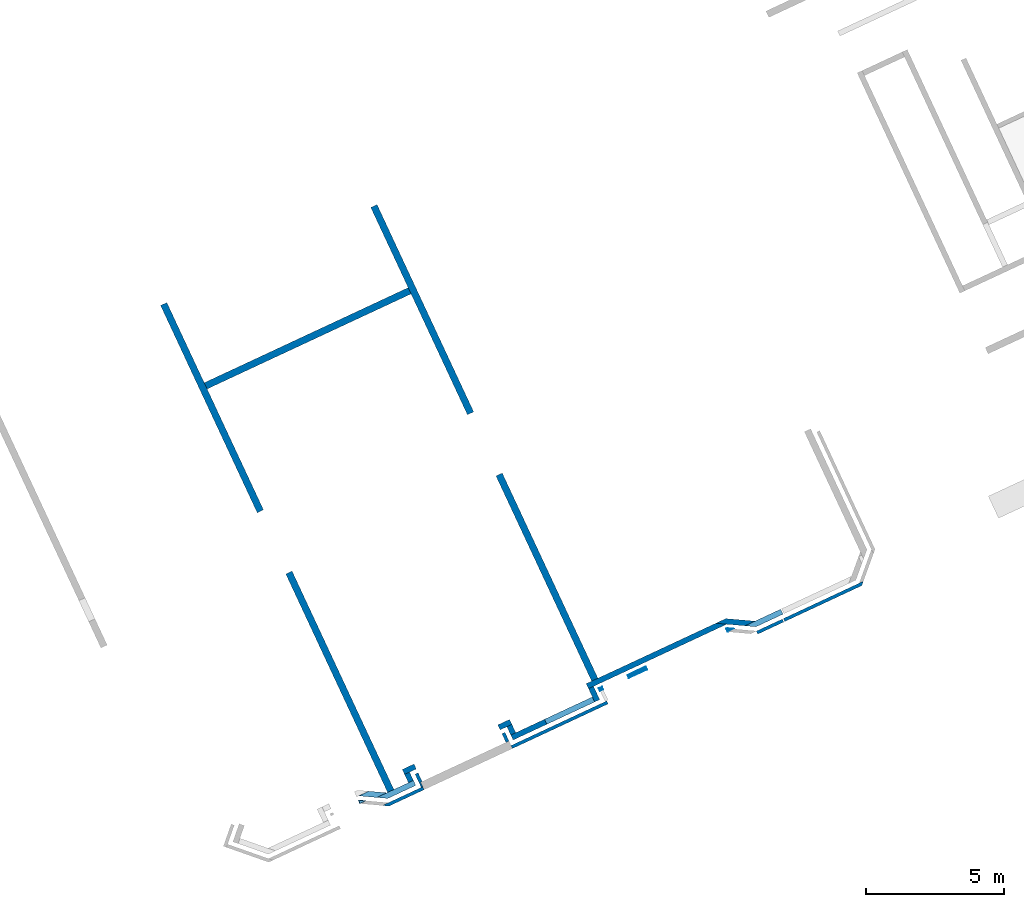
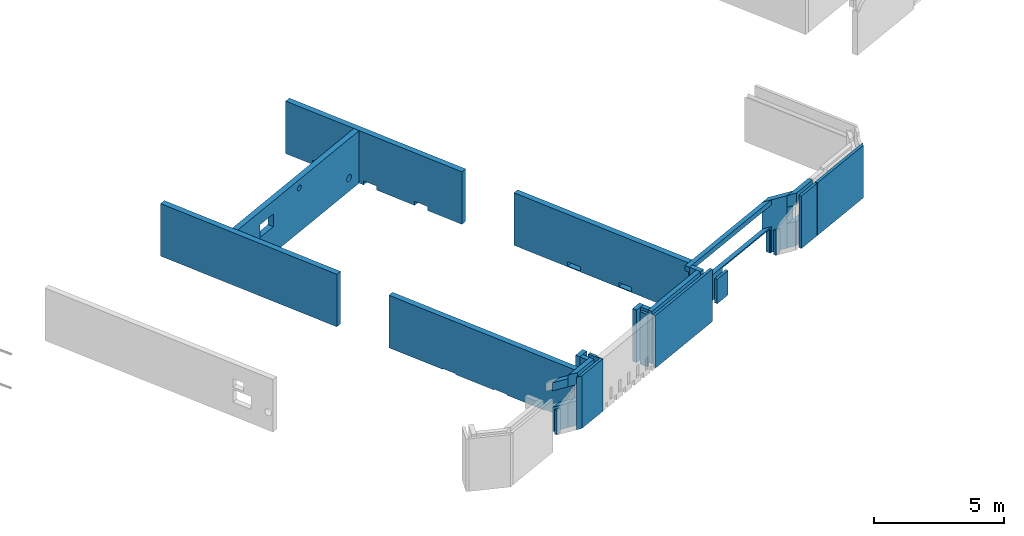
# One storey, part 2 of 13: 24 walls, 23 openings.
"""IFC2X3 building model written with IfcOpenShell, lengths in metres."""

from ifc_helpers import new_model, entity, si_unit, converted_unit, derived_unit, direction, frame, frame_2d, origin, origin_2d_with_axis, place, context, subcontext, project, spatial, polyline, rectangle, circle, outline, extrude, clip, halfspace, bounded_halfspace, material, layer, layer_set, layer_usage, type_object, element, save


model = new_model("IFC2X3")

# Units and contexts
model_context = context("Model", 3, precision=1e-05, world=origin(), true_north=direction((6.12303176911189e-17, 1.0)))
body_context = subcontext(model_context, "Body", "Model", "MODEL_VIEW")
ifc_project = project(units=[si_unit("LENGTHUNIT", "METRE"), si_unit("AREAUNIT", "SQUARE_METRE"), si_unit("VOLUMEUNIT", "CUBIC_METRE"), converted_unit("PLANEANGLEUNIT", "DEGREE", entity("IfcRatioMeasure", 0.0174532925199433), si_unit("PLANEANGLEUNIT", "RADIAN"), dimensions=[0, 0, 0, 0, 0, 0, 0]), si_unit("MASSUNIT", "GRAM", prefix="KILO"), derived_unit("MASSDENSITYUNIT", [(si_unit("MASSUNIT", "GRAM", prefix="KILO"), 1), (si_unit("LENGTHUNIT", "METRE"), -3)]), si_unit("TIMEUNIT", "SECOND"), si_unit("FREQUENCYUNIT", "HERTZ"), si_unit("THERMODYNAMICTEMPERATUREUNIT", "DEGREE_CELSIUS"), derived_unit("THERMALTRANSMITTANCEUNIT", [(si_unit("MASSUNIT", "GRAM", prefix="KILO"), 1), (si_unit("THERMODYNAMICTEMPERATUREUNIT", "KELVIN"), -1), (si_unit("TIMEUNIT", "SECOND"), -3)]), derived_unit("VOLUMETRICFLOWRATEUNIT", [(si_unit("LENGTHUNIT", "METRE"), 3), (si_unit("TIMEUNIT", "SECOND"), -1)]), si_unit("ELECTRICCURRENTUNIT", "AMPERE"), si_unit("ELECTRICVOLTAGEUNIT", "VOLT"), si_unit("POWERUNIT", "WATT"), si_unit("FORCEUNIT", "NEWTON", prefix="KILO"), si_unit("ILLUMINANCEUNIT", "LUX"), si_unit("LUMINOUSFLUXUNIT", "LUMEN"), si_unit("LUMINOUSINTENSITYUNIT", "CANDELA"), derived_unit("USERDEFINED", [(si_unit("MASSUNIT", "GRAM", prefix="KILO"), -1), (si_unit("LENGTHUNIT", "METRE"), -2), (si_unit("TIMEUNIT", "SECOND"), 3), (si_unit("LUMINOUSFLUXUNIT", "LUMEN"), 1)]), derived_unit("LINEARVELOCITYUNIT", [(si_unit("LENGTHUNIT", "METRE"), 1), (si_unit("TIMEUNIT", "SECOND"), -1)]), si_unit("PRESSUREUNIT", "PASCAL"), derived_unit("USERDEFINED", [(si_unit("LENGTHUNIT", "METRE"), -2), (si_unit("MASSUNIT", "GRAM", prefix="KILO"), 1), (si_unit("TIMEUNIT", "SECOND"), -2)])], contexts=[model_context])

# Site, building, storey
site_placement = place(None, frame((5.36960000000003, 43.3158000000006, 0.0), z_axis=(0.0, 0.0, 1.0), x_axis=(-0.422618261740703, 0.906307787036648, 0.0)))
site = spatial("IfcSite", under=ifc_project, at=site_placement, CompositionType="ELEMENT")
building_placement = place(site_placement, origin())
building = spatial("IfcBuilding", under=site, at=building_placement, CompositionType="ELEMENT")
storey_placement = place(building_placement, frame((0.0, 0.0, 2.56)))
storey = spatial("IfcBuildingStorey", under=building, at=storey_placement, CompositionType="ELEMENT", Elevation=2.56)

# Wall
ifc_material_1 = material(Name="C30/37 XC1")
ifc_layer_1 = layer(ifc_material_1, 0.25)
ifc_layer_set_1 = layer_set([ifc_layer_1])
ifc_layer_usage_1 = layer_usage(ifc_layer_set_1, "AXIS2", "NEGATIVE", 0.125)
wall_type_1 = type_object("IfcWallType", PredefinedType="NOTDEFINED", material=ifc_layer_set_1)
wall_1_placement = place(storey_placement, frame((11.6451948234783, 43.2325258490259, 0.0)))
element("IfcWallStandardCase", 1, at=wall_1_placement, inside=storey, type_object=wall_type_1, material=ifc_layer_usage_1, Name="XS1", context=body_context, shape_type="Clipping", body=[
    clip(extrude(rectangle(XDim=8.28555777301309, YDim=0.249999999999995, at=frame_2d((4.14277888650655, -1.9220736113823e-15), x_axis=(-1.0, 0.0))), origin(), (0.0, 0.0, 1.0), 2.47), halfspace(frame((0.0, 0.0, -2.56)), True)),
])

# Wall, openings
ifc_layer_usage_2 = layer_usage(ifc_layer_set_1, "AXIS2", "NEGATIVE", 0.125)
wall_2_placement = place(storey_placement, frame((0.470660848237759, 43.232525849026, 0.0)))
wall_2 = element("IfcWallStandardCase", 2, at=wall_2_placement, inside=storey, type_object=wall_type_1, material=ifc_layer_usage_2, Name="XS1", context=body_context, shape_type="Clipping", body=[
    clip(extrude(rectangle(XDim=8.73000078564873, YDim=0.249999999999995, at=frame_2d((4.36500039282437, -1.66533453693773e-16), x_axis=(-1.0, 0.0))), origin(), (0.0, 0.0, 1.0), 2.47), halfspace(frame((0.0, 0.0, -2.56)), True)),
])
opening_1_placement = place(wall_2_placement, origin())
element("IfcOpeningElement", 3, at=opening_1_placement, cuts=wall_2, Name="XS1", ObjectType="Opening", context=body_context, shape_type="SweptSolid", body=[
    extrude(rectangle(XDim=0.2, YDim=0.6, at=frame_2d((0.0, -2.70616862252382e-16), x_axis=(0.0, 1.0))), frame((1.09611385664153, -1.39899999999999, -0.0599998535014134), z_axis=(0.0, 1.0, 0.0), x_axis=(-1.0, 0.0, 0.0)), (0.0, 0.0, 1.0), 3.048),
])
opening_2_placement = place(wall_2_placement, origin())
element("IfcOpeningElement", 4, at=opening_2_placement, cuts=wall_2, Name="XS1", ObjectType="Opening", context=body_context, shape_type="SweptSolid", body=[
    extrude(rectangle(XDim=0.199999999999999, YDim=0.6, at=frame_2d((0.0, 2.70616862252382e-16), x_axis=(0.0, 1.0))), frame((3.49611385664154, -1.39899999999999, -0.0599998535014101), z_axis=(0.0, 1.0, 0.0), x_axis=(-1.0, 0.0, 0.0)), (0.0, 0.0, 1.0), 3.048),
])
opening_3_placement = place(wall_2_placement, origin())
element("IfcOpeningElement", 5, at=opening_3_placement, cuts=wall_2, Name="XS1", ObjectType="Opening", context=body_context, shape_type="SweptSolid", body=[
    extrude(rectangle(XDim=0.2, YDim=0.6, at=frame_2d((0.0, -2.70616862252382e-16), x_axis=(0.0, 1.0))), frame((5.89612088386859, -1.39899999999999, -0.0599998535014058), z_axis=(0.0, 1.0, 0.0), x_axis=(-1.0, 0.0, 0.0)), (0.0, 0.0, 1.0), 3.048),
])

ifc_layer_usage_3 = layer_usage(ifc_layer_set_1, "AXIS2", "NEGATIVE", 0.125)
wall_3_placement = place(storey_placement, frame((11.6451948234783, 34.8325258490247, 0.0)))
wall_3 = element("IfcWallStandardCase", 6, at=wall_3_placement, inside=storey, type_object=wall_type_1, material=ifc_layer_usage_3, Name="XS1", context=body_context, shape_type="Clipping", body=[
    clip(extrude(rectangle(XDim=8.28555777301365, YDim=0.250000000000004, at=frame_2d((4.14277888650682, 2.35922392732846e-16), x_axis=(-1.0, 0.0))), origin(), (0.0, 0.0, 1.0), 2.47), halfspace(frame((0.0, 0.0, -2.56)), True)),
])
opening_4_placement = place(wall_3_placement, origin())
element("IfcOpeningElement", 7, at=opening_4_placement, cuts=wall_3, Name="XS1", ObjectType="Opening", context=body_context, shape_type="SweptSolid", body=[
    extrude(rectangle(XDim=0.2, YDim=0.6, at=frame_2d((-1.08246744900953e-15, -2.70616862252382e-16), x_axis=(0.0, 1.0))), frame((1.92155925180208, -1.39899999999999, 0.0900000718130875), z_axis=(0.0, 1.0, 0.0), x_axis=(-1.0, 0.0, 0.0)), (0.0, 0.0, 1.0), 3.048),
])
opening_5_placement = place(wall_3_placement, origin())
element("IfcOpeningElement", 8, at=opening_5_placement, cuts=wall_3, Name="XS1", ObjectType="Opening", context=body_context, shape_type="SweptSolid", body=[
    extrude(rectangle(XDim=0.199999999999999, YDim=0.6, at=frame_2d((-1.08246744900953e-15, 2.70616862252382e-16), x_axis=(0.0, 1.0))), frame((4.32155925180209, -1.399, 0.0900000718130908), z_axis=(0.0, 1.0, 0.0), x_axis=(-1.0, 0.0, 0.0)), (0.0, 0.0, 1.0), 3.048),
])
opening_6_placement = place(wall_3_placement, origin())
element("IfcOpeningElement", 9, at=opening_6_placement, cuts=wall_3, Name="XS1", ObjectType="Opening", context=body_context, shape_type="SweptSolid", body=[
    extrude(rectangle(XDim=0.2, YDim=0.6, at=frame_2d((-1.08246744900953e-15, -2.70616862252382e-16), x_axis=(0.0, 1.0))), frame((6.72157988490444, -1.399, 0.0900000718130951), z_axis=(0.0, 1.0, 0.0), x_axis=(-1.0, 0.0, 0.0)), (0.0, 0.0, 1.0), 3.048),
])

ifc_layer_usage_4 = layer_usage(ifc_layer_set_1, "AXIS2", "NEGATIVE", 0.125)
wall_4_placement = place(storey_placement, frame((1.00066044225106, 34.8325258490248, 0.0)))
wall_4 = element("IfcWallStandardCase", 10, at=wall_4_placement, inside=storey, type_object=wall_type_1, material=ifc_layer_usage_4, Name="XS1", context=body_context, shape_type="Clipping", body=[
    clip(extrude(rectangle(XDim=8.20000119163591, YDim=0.250000000000004, at=frame_2d((4.10000059581795, -9.71445146547012e-17), x_axis=(-1.0, 0.0))), origin(), (0.0, 0.0, 1.0), 2.47), halfspace(frame((0.0, 0.0, -2.56)), True)),
])
opening_7_placement = place(wall_4_placement, origin())
element("IfcOpeningElement", 11, at=opening_7_placement, cuts=wall_4, Name="XS1", ObjectType="Opening", context=body_context, shape_type="SweptSolid", body=[
    extrude(rectangle(XDim=0.2, YDim=0.6, at=frame_2d((0.0, -2.70616862252382e-16), x_axis=(0.0, 1.0))), frame((0.5661142768775, -1.399, 0.140000071813087), z_axis=(0.0, 1.0, 0.0), x_axis=(-1.0, 0.0, 0.0)), (0.0, 0.0, 1.0), 3.048),
])
opening_8_placement = place(wall_4_placement, origin())
element("IfcOpeningElement", 12, at=opening_8_placement, cuts=wall_4, Name="XS1", ObjectType="Opening", context=body_context, shape_type="SweptSolid", body=[
    extrude(rectangle(XDim=0.199999999999999, YDim=0.6, at=frame_2d((0.0, 2.70616862252382e-16), x_axis=(0.0, 1.0))), frame((2.96611427687751, -1.399, 0.14000007181309), z_axis=(0.0, 1.0, 0.0), x_axis=(-1.0, 0.0, 0.0)), (0.0, 0.0, 1.0), 3.048),
])
opening_9_placement = place(wall_4_placement, origin())
element("IfcOpeningElement", 13, at=opening_9_placement, cuts=wall_4, Name="XS1", ObjectType="Opening", context=body_context, shape_type="SweptSolid", body=[
    extrude(rectangle(XDim=0.2, YDim=0.6, at=frame_2d((0.0, -2.70616862252382e-16), x_axis=(0.0, 1.0))), frame((5.36988490365039, -1.399, 0.140000071813095), z_axis=(0.0, 1.0, 0.0), x_axis=(-1.0, 0.0, 0.0)), (0.0, 0.0, 1.0), 3.048),
])

ifc_layer_usage_5 = layer_usage(ifc_layer_set_1, "AXIS2", "NEGATIVE", 0.125)
wall_5_placement = place(storey_placement, frame((16.6006608482378, 43.1075258490258, 0.0), z_axis=(0.0, 0.0, 1.0), x_axis=(0.0, -1.0, 0.0)))
wall_5 = element("IfcWallStandardCase", 14, at=wall_5_placement, inside=storey, type_object=wall_type_1, material=ifc_layer_usage_5, context=body_context, shape_type="Clipping", body=[
    clip(extrude(rectangle(XDim=8.15000000000114, YDim=0.25, at=frame_2d((4.07500000000057, -2.91433543964104e-16), x_axis=(-1.0, 0.0))), origin(), (0.0, 0.0, 1.0), 2.47), halfspace(frame((0.0, 0.0, -2.56)), True)),
])
opening_10_placement = place(wall_5_placement, origin())
element("IfcOpeningElement", 15, at=opening_10_placement, cuts=wall_5, ObjectType="Opening", context=body_context, shape_type="SweptSolid", body=[
    extrude(rectangle(XDim=0.6, YDim=0.900000000000003, at=origin_2d_with_axis()), frame((1.93568360081776, -1.649, 1.56000262207879), z_axis=(0.0, 1.0, 0.0), x_axis=(0.0, 0.0, 1.0)), (0.0, 0.0, 1.0), 3.048),
])
opening_11_placement = place(wall_5_placement, origin())
element("IfcOpeningElement", 16, at=opening_11_placement, cuts=wall_5, ObjectType="Opening", context=body_context, shape_type="SweptSolid", body=[
    extrude(circle(Radius=0.125, at=frame_2d((0.0, -5.41433564649196e-16), x_axis=(1.0, 0.0))), frame((4.13951247206561, -1.649, 2.07863766127968), z_axis=(0.0, 1.0, 0.0), x_axis=(1.0, 0.0, 0.0)), (0.0, 0.0, 1.0), 3.048),
])
opening_12_placement = place(wall_5_placement, origin())
element("IfcOpeningElement", 17, at=opening_12_placement, cuts=wall_5, ObjectType="Opening", context=body_context, shape_type="SweptSolid", body=[
    extrude(circle(Radius=0.1575, at=frame_2d((0.0, -1.08286712929839e-15), x_axis=(1.0, 0.0))), frame((7.47164763057468, -1.649, 0.630276585337193), z_axis=(0.0, 1.0, 0.0), x_axis=(1.0, 0.0, 0.0)), (0.0, 0.0, 1.0), 3.048),
])

# Wall, opening
ifc_material_2 = material(Name="C30/37 XS1")
ifc_layer_2 = layer(ifc_material_2, 0.2)
ifc_layer_set_2 = layer_set([ifc_layer_2])
ifc_layer_usage_6 = layer_usage(ifc_layer_set_2, "AXIS2", "NEGATIVE", 0.0999999999999944)
wall_type_2 = type_object("IfcWallType", PredefinedType="STANDARD", material=ifc_layer_set_2)
wall_6_placement = place(storey_placement, frame((0.370206914268475, 29.0775146983253, 0.0), z_axis=(0.0, 0.0, 1.0), x_axis=(0.0, -1.0, 0.0)))
wall_6 = element("IfcWallStandardCase", 18, at=wall_6_placement, inside=storey, type_object=wall_type_2, material=ifc_layer_usage_6, context=body_context, shape_type="Clipping", body=[
    clip(extrude(outline(polyline([(1.42498884913272, -0.0999999999999944), (1.42498884913272, 0.0999999999999944), (0.400000000002693, 0.0999999999999944), (0.0, 0.0999999999999944), (0.346410161516894, -0.0999999999999944), (1.42498884913272, -0.0999999999999944)])), origin(), (0.0, 0.0, 1.0), 2.47), halfspace(frame((0.0, 0.0, -2.56)), True)),
])
opening_13_placement = place(storey_placement, frame((0.370206914268475, 29.0775146983253, 0.0), z_axis=(0.0, 0.0, 1.0), x_axis=(0.0, -1.0, 0.0)))
element("IfcOpeningElement", 19, at=opening_13_placement, cuts=wall_6, ObjectType="Opening", context=body_context, shape_type="SweptSolid", body=[
    extrude(outline(polyline([(-0.452686803428687, -0.0999999999999943), (0.625891884187142, -0.0999999999999943), (0.62589188418714, 0.0999999999999945), (-0.799096964945581, 0.0999999999999944), (-0.452686803428687, -0.0999999999999943)])), frame((0.799096964945581, 0.0, 1.15)), (0.0, 0.0, 1.0), 0.77),
])

ifc_layer_usage_7 = layer_usage(ifc_layer_set_2, "AXIS2", "NEGATIVE", 0.0999999999999944)
wall_7_placement = place(storey_placement, frame((1.08726298262964, 29.9462871598539, 0.0), z_axis=(0.0, 0.0, 1.0), x_axis=(-0.49999999999661, -0.866025403786396, 0.0)))
wall_7 = element("IfcWallStandardCase", 20, at=wall_7_placement, inside=storey, type_object=wall_type_2, material=ifc_layer_usage_7, context=body_context, shape_type="Clipping", body=[
    clip(extrude(outline(polyline([(1.06090705597228, -0.0999999999999937), (1.40731721748917, 0.0999999999999943), (0.346410161516892, 0.0999999999999941), (0.0, -0.0999999999999938), (0.400000000002694, -0.0999999999999939), (1.06090705597228, -0.0999999999999937)])), origin(), (0.0, 0.0, 1.0), 2.47), halfspace(frame((0.0, 0.0, -2.56)), True)),
])
opening_14_placement = place(wall_7_placement, origin())
element("IfcOpeningElement", 21, at=opening_14_placement, cuts=wall_7, ObjectType="Opening", context=body_context, shape_type="SweptSolid", body=[
    extrude(rectangle(XDim=2.56, YDim=3.22, at=frame_2d((0.0, 2.1094237467878e-15), x_axis=(1.0, 0.0))), frame((-1.0686392535104, -0.947919268350552, -0.13), z_axis=(-0.499999999996602, 0.8660254037864, 0.0), x_axis=(0.0, 0.0, -1.0)), (0.0, 0.0, 1.0), 0.199999999999986),
])

# Wall, openings
ifc_layer_usage_8 = layer_usage(ifc_layer_set_2, "AXIS2", "NEGATIVE", 0.0999999999999944)
wall_8_placement = place(storey_placement, frame((0.900660442251067, 35.1755037603071, 0.0), z_axis=(0.0, 0.0, 1.0), x_axis=(0.0, -1.0, 0.0)))
wall_8 = element("IfcWallStandardCase", 22, at=wall_8_placement, inside=storey, type_object=wall_type_2, material=ifc_layer_usage_8, context=body_context, shape_type="Clipping", body=[
    clip(extrude(outline(polyline([(5.52562676197045, -0.0999999999999943), (5.17921660045356, 0.0999999999999945), (0.0, 0.0999999999999945), (0.0, -0.0999999999999943), (0.19999999999999, -0.0999999999999943), (5.52562676197045, -0.0999999999999943)])), origin(), (0.0, 0.0, 1.0), 2.47), halfspace(frame((0.0, 0.0, -2.56)), True)),
])
opening_15_placement = place(storey_placement, frame((0.900660442251067, 35.1755037603071, 0.0), z_axis=(0.0, 0.0, 1.0), x_axis=(0.0, -1.0, 0.0)))
element("IfcOpeningElement", 23, at=opening_15_placement, cuts=wall_8, ObjectType="Opening", context=body_context, shape_type="SweptSolid", body=[
    extrude(outline(polyline([(-2.676210840606, -0.0999999999999947), (2.84941592136445, -0.0999999999999942), (2.50300575984755, 0.0999999999999945), (-2.676210840606, 0.099999999999994), (-2.676210840606, -0.0999999999999947)])), frame((2.676210840606, 0.0, 1.212)), (0.0, 0.0, 1.0), 1.018),
])
opening_16_placement = place(wall_8_placement, origin())
element("IfcOpeningElement", 24, at=opening_16_placement, cuts=wall_8, ObjectType="Opening", context=body_context, shape_type="SweptSolid", body=[
    extrude(rectangle(XDim=2.56, YDim=3.22, at=frame_2d((0.0, -2.1094237467878e-15), x_axis=(1.0, 0.0))), frame((3.82978822525781, -1.42400000000001, -0.13), z_axis=(0.0, 1.0, 0.0), x_axis=(0.0, 0.0, -1.0)), (0.0, 0.0, 1.0), 3.048),
])
opening_17_placement = place(wall_8_placement, origin())
element("IfcOpeningElement", 25, at=opening_17_placement, cuts=wall_8, ObjectType="Opening", context=body_context, shape_type="SweptSolid", body=[
    extrude(rectangle(XDim=2.56, YDim=1.02, at=origin_2d_with_axis()), frame((0.979807850942328, -1.42400000000001, -0.13), z_axis=(0.0, 1.0, 0.0), x_axis=(0.0, 0.0, -1.0)), (0.0, 0.0, 1.0), 3.048),
])

# Wall
ifc_layer_usage_9 = layer_usage(ifc_layer_set_2, "AXIS2", "NEGATIVE", 0.0999999999999944)
wall_9_placement = place(storey_placement, frame((0.270660848237692, 35.0755037603071, 0.0)))
element("IfcWallStandardCase", 26, at=wall_9_placement, inside=storey, type_object=wall_type_2, material=ifc_layer_usage_9, context=body_context, shape_type="Clipping", body=[
    clip(extrude(rectangle(XDim=0.52999959401338, YDim=0.199999999999989, at=frame_2d((0.26499979700669, 3.95516952522712e-16), x_axis=(-1.0, 0.0))), origin(), (0.0, 0.0, 1.0), 2.47), halfspace(frame((0.0, 0.0, -2.56)), True)),
])

# Wall, opening
ifc_layer_usage_10 = layer_usage(ifc_layer_set_2, "AXIS2", "NEGATIVE", 0.0999999999999944)
wall_10_placement = place(storey_placement, frame((0.370660848237719, 38.4375258489131, 0.0), z_axis=(0.0, 0.0, 1.0), x_axis=(0.0, -1.0, 0.0)))
wall_10 = element("IfcWallStandardCase", 27, at=wall_10_placement, inside=storey, type_object=wall_type_2, material=ifc_layer_usage_10, context=body_context, shape_type="Clipping", body=[
    clip(extrude(rectangle(XDim=3.26202208860598, YDim=0.199999999999989, at=frame_2d((1.63101104430299, -3.46944695195361e-17), x_axis=(-1.0, 0.0))), origin(), (0.0, 0.0, 1.0), 2.47000000001082), halfspace(frame((0.0, 0.0, -2.56)), True)),
])
opening_18_placement = place(storey_placement, frame((0.370660848237719, 38.4375258489131, 0.0), z_axis=(0.0, 0.0, 1.0), x_axis=(0.0, -1.0, 0.0)))
element("IfcOpeningElement", 28, at=opening_18_placement, cuts=wall_10, ObjectType="Opening", context=body_context, shape_type="SweptSolid", body=[
    extrude(outline(polyline([(-0.0661632677345893, -0.187340696214586), (0.133081633867332, -0.187340696214586), (0.133081633867256, 1.72468139241028), (-0.0669183661327325, 1.72468139241027), (-0.0669183661326932, -1.53734069619571), (-0.066163267734573, -1.53734069619571), (-0.0661632677345893, -0.187340696214586)])), frame((1.53734069619571, 0.0330816338672827, 1.15), z_axis=(0.0, 0.0, 1.0), x_axis=(0.0, -1.0, 0.0)), (0.0, 0.0, 1.0), 0.77),
])

# Walls
ifc_layer_usage_11 = layer_usage(ifc_layer_set_2, "AXIS2", "NEGATIVE", 0.0999999999999944)
wall_11_placement = place(storey_placement, frame((0.800660848237638, 38.3375258489131, 0.0), z_axis=(0.0, 0.0, 1.0), x_axis=(-1.0, 0.0, 0.0)))
element("IfcWallStandardCase", 29, at=wall_11_placement, inside=storey, type_object=wall_type_2, material=ifc_layer_usage_11, context=body_context, shape_type="Clipping", body=[
    clip(extrude(rectangle(XDim=0.329999999999926, YDim=0.199999999999989, at=frame_2d((0.164999999999963, -5.68989300120393e-16), x_axis=(-1.0, 0.0))), origin(), (0.0, 0.0, 1.0), 2.47), halfspace(frame((0.0, 0.0, -2.56)), True)),
])
ifc_layer_usage_12 = layer_usage(ifc_layer_set_2, "AXIS2", "NEGATIVE", 0.0999999999999944)
wall_12_placement = place(storey_placement, frame((0.900660848237636, 38.7075258489317, 0.0), z_axis=(0.0, 0.0, 1.0), x_axis=(0.0, -1.0, 0.0)))
element("IfcWallStandardCase", 30, at=wall_12_placement, inside=storey, type_object=wall_type_2, material=ifc_layer_usage_12, context=body_context, shape_type="Clipping", body=[
    clip(extrude(rectangle(XDim=0.470000000018614, YDim=0.199999999999989, at=frame_2d((0.235000000009307, -2.08166817117217e-17), x_axis=(-1.0, 0.0))), origin(), (0.0, 0.0, 1.0), 2.47), halfspace(frame((0.0, 0.0, -2.56)), True)),
])

# Wall, opening
ifc_layer_usage_13 = layer_usage(ifc_layer_set_2, "AXIS2", "NEGATIVE", 0.0999999999999944)
wall_13_placement = place(storey_placement, frame((0.384058307870648, 43.4400967879065, 0.0), z_axis=(0.0, 0.0, 1.0), x_axis=(0.500000000196137, 0.866025403671199, 0.0)))
wall_13 = element("IfcWallStandardCase", 31, at=wall_13_placement, inside=storey, type_object=wall_type_2, material=ifc_layer_usage_13, context=body_context, shape_type="Clipping", body=[
    clip(clip(extrude(outline(polyline([(0.659999999740961, -0.0999999999999935), (1.00641016107353, 0.0999999999999938), (0.346410161332573, 0.0999999999999926), (0.0, -0.0999999999999935), (0.659999999740961, -0.0999999999999935)])), origin(), (0.0, 0.0, 1.0), 2.3), bounded_halfspace(frame((0.0, -0.0999999999999903, 2.3), z_axis=(0.0, 0.0, -1.0), x_axis=(0.500000000196127, -0.866025403671205, 0.0)), True, frame((0.0, -0.0999999999999903, 2.3), z_axis=(0.0, 0.0, -1.0), x_axis=(0.500000000196127, -0.866025403671205, 0.0)), polyline([(0.0, 0.0), (0.0, -0.399999999843067), (0.329999999999923, -0.971576766041727), (0.329999999999919, -0.77157676612019), (0.329999999999922, -0.571576766198648), (0.0, 0.0)]))), halfspace(frame((0.0, 0.0, -2.56)), True)),
])
opening_19_placement = place(storey_placement, frame((0.384058307870648, 43.4400967879065, 0.0), z_axis=(0.0, 0.0, 1.0), x_axis=(0.500000000196137, 0.866025403671199, 0.0)))
element("IfcOpeningElement", 32, at=opening_19_placement, cuts=wall_13, ObjectType="Opening", context=body_context, shape_type="SweptSolid", body=[
    extrude(outline(polyline([(-0.503205080536765, -0.099999999999995), (0.156794919204185, -0.0999999999999952), (0.503205080536767, 0.0999999999999925), (-0.156794919204194, 0.0999999999999934), (-0.503205080536765, -0.099999999999995)])), frame((0.503205080536767, 0.0, 1.15)), (0.0, 0.0, 1.0), 0.77),
])

ifc_layer_usage_14 = layer_usage(ifc_layer_set_2, "AXIS2", "NEGATIVE", 0.0999999999999944)
wall_14_placement = place(storey_placement, frame((0.370660848237756, 42.3275258490435, 0.0), z_axis=(0.0, 0.0, 1.0), x_axis=(0.0, 1.0, 0.0)))
wall_14 = element("IfcWallStandardCase", 33, at=wall_14_placement, inside=storey, type_object=wall_type_2, material=ifc_layer_usage_14, context=body_context, shape_type="Clipping", body=[
    clip(extrude(outline(polyline([(1.46257093868644, -0.0999999999999945), (1.11616077735387, 0.0999999999999944), (0.0, 0.0999999999999944), (0.0, -0.0999999999999945), (0.19999999999999, -0.0999999999999944), (1.06257093884338, -0.0999999999999945), (1.46257093868644, -0.0999999999999945)])), origin(), (0.0, 0.0, 1.0), 2.47), halfspace(frame((0.0, 0.0, -2.56)), True)),
])
opening_20_placement = place(storey_placement, frame((0.370660848237756, 42.3275258490435, 0.0), z_axis=(0.0, 0.0, 1.0), x_axis=(0.0, 1.0, 0.0)))
element("IfcOpeningElement", 34, at=opening_20_placement, cuts=wall_14, ObjectType="Opening", context=body_context, shape_type="SweptSolid", body=[
    extrude(outline(polyline([(-0.60688377581395, -0.0667925163996833), (0.455687163029426, -0.0667925163996832), (0.855687162872493, -0.0667925163996832), (0.509277001539915, 0.133207483600307), (-0.606883775813952, 0.133207483600306), (-0.60688377581395, -0.066037418001563), (-0.60688377581395, -0.0667925163996833)])), frame((0.60688377581395, -0.0332074836003112, 1.15)), (0.0, 0.0, 1.0), 0.77),
])

# Walls
ifc_layer_usage_15 = layer_usage(ifc_layer_set_2, "AXIS2", "NEGATIVE", 0.0999999999999944)
wall_15_placement = place(storey_placement, frame((0.470660848237752, 42.4275258490435, 0.0)))
element("IfcWallStandardCase", 35, at=wall_15_placement, inside=storey, type_object=wall_type_2, material=ifc_layer_usage_15, context=body_context, shape_type="Clipping", body=[
    clip(extrude(rectangle(XDim=0.329999999999925, YDim=0.199999999999989, at=frame_2d((0.164999999999963, -2.73392419813945e-15), x_axis=(-1.0, 0.0))), origin(), (0.0, 0.0, 1.0), 2.47), halfspace(frame((0.0, 0.0, -2.56)), True)),
])
ifc_layer_usage_16 = layer_usage(ifc_layer_set_2, "AXIS2", "NEGATIVE", 0.0999999999999944)
wall_16_placement = place(storey_placement, frame((0.900660848237673, 42.5275258490435, 0.0), z_axis=(0.0, 0.0, 1.0), x_axis=(0.0, -1.0, 0.0)))
element("IfcWallStandardCase", 36, at=wall_16_placement, inside=storey, type_object=wall_type_2, material=ifc_layer_usage_16, context=body_context, shape_type="Clipping", body=[
    clip(extrude(rectangle(XDim=0.470000000018605, YDim=0.199999999999989, at=frame_2d((0.235000000009303, -2.08166817117217e-17), x_axis=(-1.0, 0.0))), origin(), (0.0, 0.0, 1.0), 2.47), halfspace(frame((0.0, 0.0, -2.56)), True)),
])
ifc_layer_3 = layer(ifc_material_2, 0.12)
ifc_layer_set_3 = layer_set([ifc_layer_3])
ifc_layer_usage_17 = layer_usage(ifc_layer_set_3, "AXIS2", "NEGATIVE", 0.06)
wall_type_3 = type_object("IfcWallType", PredefinedType="STANDARD", material=ifc_layer_set_3)
wall_17_placement = place(storey_placement, frame((0.0606608482377209, 42.1175258490249, 0.0), z_axis=(0.0, 0.0, 1.0), x_axis=(0.0, 1.0, 0.0)))
element("IfcWallStandardCase", 37, at=wall_17_placement, inside=storey, type_object=wall_type_3, material=ifc_layer_usage_17, context=body_context, shape_type="Clipping", body=[
    clip(extrude(outline(polyline([(1.61304166344481, -0.06), (1.40519556653568, 0.06), (0.0, 0.06), (0.0, -0.06), (0.0600000000000043, -0.06), (1.37304166344406, -0.06), (1.61304166344481, -0.06)])), origin(), (0.0, 0.0, 1.0), 2.47), halfspace(frame((0.0, 0.0, -2.56)), True)),
])
ifc_layer_usage_18 = layer_usage(ifc_layer_set_3, "AXIS2", "NEGATIVE", 0.06)
wall_18_placement = place(storey_placement, frame((0.120660848237721, 42.1175258490249, 0.0)))
element("IfcWallStandardCase", 38, at=wall_18_placement, inside=storey, type_object=wall_type_3, material=ifc_layer_usage_18, context=body_context, shape_type="Clipping", body=[
    clip(extrude(outline(polyline([(0.530000000000386, -0.0599999999999986), (0.530000000000386, 0.0600000000000002), (0.0, 0.0600000000000037), (0.0, 0.0), (0.18000000000015, 0.0), (0.18000000000015, -0.0600000000000019), (0.530000000000386, -0.0599999999999986)])), origin(), (0.0, 0.0, 1.0), 2.47), halfspace(frame((0.0, 0.0, -2.56)), True)),
])

# Wall, opening
ifc_layer_usage_19 = layer_usage(ifc_layer_set_3, "AXIS2", "NEGATIVE", 0.06)
wall_19_placement = place(storey_placement, frame((0.590752216828904, 44.2008665986172, 0.0), z_axis=(0.0, 0.0, 1.0), x_axis=(0.0, 1.0, 0.0)))
wall_19 = element("IfcWallStandardCase", 39, at=wall_19_placement, inside=storey, type_object=wall_type_3, material=ifc_layer_usage_19, context=body_context, shape_type="Clipping", body=[
    clip(extrude(outline(polyline([(1.26000000000104, -0.06), (1.26000000000104, 0.06), (0.240000000000751, 0.0600000000000001), (0.0, 0.06), (0.207846096909137, -0.06), (1.26000000000104, -0.06)])), origin(), (0.0, 0.0, 1.0), 1.15), halfspace(frame((0.0, 0.0, -2.56)), True)),
])
opening_21_placement = place(wall_19_placement, origin())
element("IfcOpeningElement", 40, at=opening_21_placement, cuts=wall_19, ObjectType="Opening", context=body_context, shape_type="SweptSolid", body=[
    extrude(rectangle(XDim=2.56, YDim=1.02, at=frame_2d((4.32986979603811e-15, 0.0), x_axis=(0.0, 1.0))), frame((0.750000000001034, -1.584, -0.13), z_axis=(0.0, 1.0, 0.0), x_axis=(1.0, 0.0, 0.0)), (0.0, 0.0, 1.0), 3.048),
])

# Walls
ifc_layer_usage_20 = layer_usage(ifc_layer_set_3, "AXIS2", "NEGATIVE", 0.06)
wall_20_placement = place(storey_placement, frame((0.650660848238073, 38.6475258490249, 0.0), z_axis=(0.0, 0.0, 1.0), x_axis=(-1.0, 0.0, 0.0)))
element("IfcWallStandardCase", 41, at=wall_20_placement, inside=storey, type_object=wall_type_3, material=ifc_layer_usage_20, context=body_context, shape_type="Clipping", body=[
    clip(extrude(rectangle(XDim=0.35000000000024, YDim=0.119999999999999, at=frame_2d((0.17500000000012, 1.69309011255336e-15), x_axis=(-1.0, 0.0))), origin(), (0.0, 0.0, 1.0), 2.47), halfspace(frame((0.0, 0.0, -2.56)), True)),
])
ifc_layer_usage_21 = layer_usage(ifc_layer_set_3, "AXIS2", "NEGATIVE", 0.06)
wall_21_placement = place(storey_placement, frame((0.0606608482376492, 34.7075258490254, 0.0), z_axis=(0.0, 0.0, 1.0), x_axis=(0.0, 1.0, 0.0)))
element("IfcWallStandardCase", 42, at=wall_21_placement, inside=storey, type_object=wall_type_3, material=ifc_layer_usage_21, context=body_context, shape_type="Clipping", body=[
    clip(clip(extrude(rectangle(XDim=3.81999999999954, YDim=0.12, at=frame_2d((1.96999999999977, 3.46944695195361e-18), x_axis=(-1.0, 0.0))), origin(), (0.0, 0.0, 1.0), 2.56), bounded_halfspace(frame((3.87999999999951, 0.0600000000044225, 2.47), z_axis=(-1.0, 0.0, 0.0), x_axis=(0.0, -1.0, 0.0)), False, frame((3.87999999999951, 0.0600000000044225, 2.47), z_axis=(-1.0, 0.0, 0.0), x_axis=(0.0, -1.0, 0.0)), polyline([(0.0, 0.0), (0.12, 0.0), (0.120000000004422, 0.0899999999999999), (0.0, 0.0899999999999999), (0.0, 0.0)]))), halfspace(frame((0.0, 0.0, -2.56)), True)),
])

# Wall, openings
ifc_layer_usage_22 = layer_usage(ifc_layer_set_3, "AXIS2", "NEGATIVE", 0.06)
wall_22_placement = place(storey_placement, frame((0.590660848237564, 34.8275258490254, 0.0), z_axis=(0.0, 0.0, 1.0), x_axis=(0.0, -1.0, 0.0)))
wall_22 = element("IfcWallStandardCase", 43, at=wall_22_placement, inside=storey, type_object=wall_type_3, material=ifc_layer_usage_22, context=body_context, shape_type="Clipping", body=[
    clip(extrude(outline(polyline([(0.0, -0.0599999999999999), (5.3453018652599, -0.0599999999999999), (5.13745576834997, 0.06), (0.0, 0.06), (0.0, -0.0599999999999999)])), origin(), (0.0, 0.0, 1.0), 1.15), halfspace(frame((0.0, 0.0, -2.56)), True)),
])
opening_22_placement = place(wall_22_placement, origin())
element("IfcOpeningElement", 44, at=opening_22_placement, cuts=wall_22, ObjectType="Opening", context=body_context, shape_type="SweptSolid", body=[
    extrude(rectangle(XDim=2.56, YDim=1.02, at=frame_2d((0.0, 2.16493489801906e-15), x_axis=(1.0, 0.0))), frame((0.631829939660573, -1.464, -0.13), z_axis=(0.0, 1.0, 0.0), x_axis=(0.0, 0.0, -1.0)), (0.0, 0.0, 1.0), 3.048),
])
opening_23_placement = place(wall_22_placement, origin())
element("IfcOpeningElement", 45, at=opening_23_placement, cuts=wall_22, ObjectType="Opening", context=body_context, shape_type="SweptSolid", body=[
    extrude(rectangle(XDim=2.56, YDim=3.22, at=frame_2d((0.0, -2.1094237467878e-15), x_axis=(1.0, 0.0))), frame((3.48181031397598, -1.464, -0.13), z_axis=(0.0, 1.0, 0.0), x_axis=(0.0, 0.0, -1.0)), (0.0, 0.0, 1.0), 3.048),
])

# Walls
ifc_layer_usage_23 = layer_usage(ifc_layer_set_3, "AXIS2", "NEGATIVE", 0.06)
wall_23_placement = place(storey_placement, frame((0.0606608482375505, 24.5074457480708, 0.0), z_axis=(0.0, 0.0, 1.0), x_axis=(0.0, 1.0, 0.0)))
element("IfcWallStandardCase", 46, at=wall_23_placement, inside=storey, type_object=wall_type_3, material=ifc_layer_usage_23, context=body_context, shape_type="Clipping", body=[
    clip(extrude(outline(polyline([(3.19996264791324, -0.06), (3.19996264791324, 0.06), (0.119999999981239, 0.06), (0.0, -0.06), (0.169705627471503, -0.06), (3.19996264791324, -0.06)])), origin(), (0.0, 0.0, 1.0), 2.47), halfspace(frame((0.0, 0.0, -2.56)), True)),
])
ifc_layer_usage_24 = layer_usage(ifc_layer_set_3, "AXIS2", "NEGATIVE", 0.06)
wall_24_placement = place(storey_placement, frame((0.0606608482375818, 27.7474083959841, 0.0), z_axis=(0.0, 0.0, 1.0), x_axis=(0.0, 1.0, 0.0)))
element("IfcWallStandardCase", 47, at=wall_24_placement, inside=storey, type_object=wall_type_3, material=ifc_layer_usage_24, context=body_context, shape_type="Clipping", body=[
    clip(extrude(rectangle(XDim=1.04075170821836, YDim=0.12, at=frame_2d((0.520375854109179, 0.0), x_axis=(-1.0, 0.0))), origin(), (0.0, 0.0, 1.0), 2.47), halfspace(frame((0.0, 0.0, -2.56)), True)),
])

save(model, "model.ifc")
